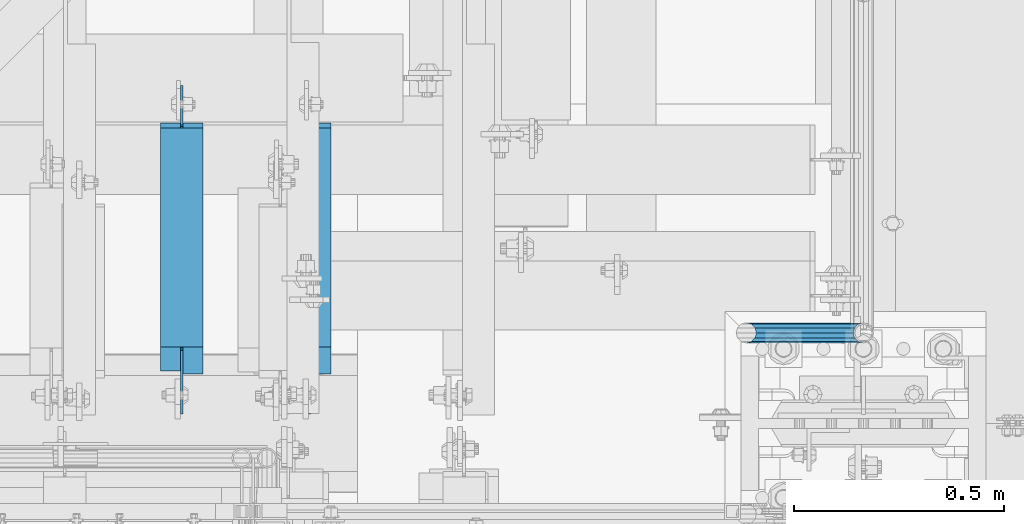
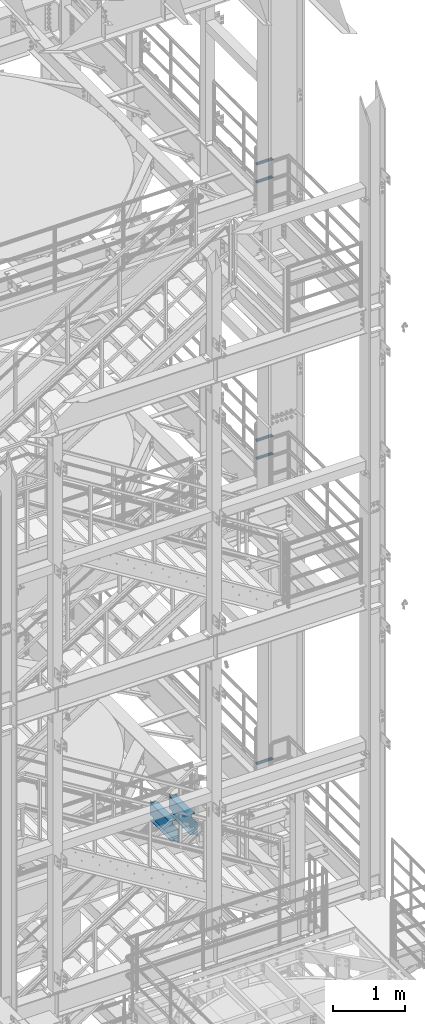
# One storey, part 1208 of 1876: 7 beams, 5 elements without a shape of their own.
"""IFC2X3 building model written with IfcOpenShell, lengths in millimetres."""

from ifc_helpers import new_model, si_unit, frame, origin_with_axes, place, context, subcontext, project, spatial, faceted_brep, material, type_object, element, aggregate, save


model = new_model("IFC2X3")

# Units and contexts
model_context = context("Model", 3, precision=1e-05, world=origin_with_axes())
body_context = subcontext(model_context, "Body", "Model", "MODEL_VIEW")
ifc_project = project(units=[si_unit("LENGTHUNIT", "METRE", prefix="MILLI"), si_unit("AREAUNIT", "SQUARE_METRE"), si_unit("VOLUMEUNIT", "CUBIC_METRE"), si_unit("MASSUNIT", "GRAM", prefix="KILO"), si_unit("TIMEUNIT", "SECOND"), si_unit("PLANEANGLEUNIT", "RADIAN"), si_unit("SOLIDANGLEUNIT", "STERADIAN"), si_unit("THERMODYNAMICTEMPERATUREUNIT", "DEGREE_CELSIUS"), si_unit("LUMINOUSINTENSITYUNIT", "LUMEN")], contexts=[model_context])

# Site, building, storey
site_placement = place(None, origin_with_axes())
site = spatial("IfcSite", under=ifc_project, at=site_placement, CompositionType="ELEMENT")
building_placement = place(site_placement, origin_with_axes())
building = spatial("IfcBuilding", under=site, at=building_placement, Name="Undefined", CompositionType="ELEMENT")
storey_placement = place(building_placement, origin_with_axes())
storey = spatial("IfcBuildingStorey", under=building, at=storey_placement, Name="Undefined", CompositionType="ELEMENT", Elevation=0.0)

# Assembly, beams
assembly_1_placement = place(storey_placement, origin_with_axes())
assembly_1 = element("IfcElementAssembly", 1, at=assembly_1_placement, inside=storey, Name="RAIL", AssemblyPlace="NOTDEFINED", PredefinedType="RIGID_FRAME")
ifc_material_1 = material()
beam_type_1 = type_object("IfcBeamType", Name="PIPE1-1/2SCH40", PredefinedType="NOTDEFINED")
beam_1_placement = place(assembly_1_placement, frame((7620.00000000001, -4356.1, 18449.925000036), z_axis=(0.0, 0.0, 1.0), x_axis=(-1.0, 0.0, 0.0)))
beam_1 = element("IfcBeam", 2, at=beam_1_placement, type_object=beam_type_1, material=ifc_material_1, Name="RAIL", ObjectType="PIPE1-1/2SCH40", context=body_context, shape_type="Brep", body=[
    faceted_brep([(258.502800903171, -12.0650000000005, 20.8971929933177), (258.502800903171, -12.0650000000005, 15.8661214311796), (258.009372465309, -10.2235000000001, 17.7076214311819), (255.26999389649, 0.0, 20.4470000000001), (255.26999389649, 0.0, 24.130000000001), (258.009372465309, 10.2235000000001, 17.7076214311819), (258.502800903171, 12.0650000000005, 15.8661214311796), (258.502800903171, 12.0650000000005, 20.8971929933177), (279.399993896489, 24.1299999999992, 0.0), (267.33499389649, 20.8971929933177, 12.0649999999987), (267.33499389649, 20.8971929933177, -12.0649999999987), (264.145422334351, 17.7076214311801, 10.2235000000001), (266.884800903171, 20.4470000000001, 0.0), (264.145422334351, 17.7076214311801, -10.2235000000001), (258.502800903171, 12.0650000000005, -15.8661214311796), (258.502800903171, 12.0650000000005, -20.8971929933177), (258.009372465309, 10.2235000000001, -17.7076214311819), (255.26999389649, 0.0, -20.4470000000001), (255.26999389649, 0.0, -24.130000000001), (258.502800903171, -12.0650000000005, -15.8661214311796), (258.502800903171, -12.0650000000005, -20.8971929933177), (258.009372465309, -10.2235000000001, -17.7076214311819), (279.399993896489, -24.1299999999992, 0.0), (267.33499389649, -20.8971929933177, -12.0649999999987), (267.33499389649, -20.8971929933177, 12.0649999999987), (264.145422334351, -17.7076214311801, -10.2235000000001), (266.884800903171, -20.4470000000001, 0.0), (264.145422334351, -17.7076214311801, 10.2235000000001), (12.0650000000064, -20.8971929933177, -12.0649999999987), (20.8971929933249, -12.0650000000005, -20.8971929933177), (0.0, 24.1299999999992, 0.0), (12.0650000000064, 20.8971929933177, -12.0649999999987), (12.0650000000064, 20.8971929933177, 12.0649999999987), (20.8971929933249, 12.0650000000005, 20.8971929933177), (24.1300000000064, 0.0, 24.130000000001), (20.8971929933249, 12.0650000000005, -20.8971929933177), (24.1300000000063, 0.0, -24.130000000001), (24.1300000000063, 0.0, -20.4470000000001), (20.8971929933249, -12.0650000000005, -15.8661214311796), (21.3906214311868, -10.2235000000001, -17.7076214311819), (21.3906214311868, 10.2235000000001, -17.7076214311819), (20.8971929933249, 12.0650000000005, -15.8661214311796), (15.2545715621445, 17.7076214311801, -10.2235000000001), (12.5151929933249, 20.4470000000001, 0.0), (15.2545715621445, 17.7076214311801, 10.2235000000001), (20.8971929933249, 12.0650000000005, 15.8661214311796), (21.3906214311868, 10.2235000000001, 17.7076214311819), (24.1300000000064, 0.0, 20.4470000000001), (21.3906214311868, -10.2235000000001, 17.7076214311819), (20.8971929933249, -12.0650000000005, 15.8661214311796), (20.8971929933249, -12.0650000000005, 20.8971929933177), (12.0650000000064, -20.8971929933177, 12.0649999999987), (0.0, -24.1299999999992, 0.0), (15.2545715621445, -17.7076214311801, 10.2235000000001), (12.5151929933249, -20.4470000000001, 0.0), (15.2545715621445, -17.7076214311801, -10.2235000000001)], [[[0, 1, 2, 3, 4]], [[4, 3, 5, 6, 7]], [[8, 9, 10]], [[7, 6, 11, 12, 13, 14, 15, 10, 9]], [[16, 17, 18, 15, 14]], [[19, 20, 18, 17, 21]], [[22, 23, 24]], [[24, 23, 20, 19, 25, 26, 27, 1, 0]], [[28, 29, 20, 23]], [[30, 31, 32]], [[33, 34, 4, 7]], [[32, 33, 7, 9]], [[30, 32, 9, 8]], [[31, 30, 8, 10]], [[35, 31, 10, 15]], [[36, 35, 15, 18]], [[29, 36, 18, 20]], [[37, 36, 29, 38, 39]], [[40, 41, 35, 36, 37]], [[32, 31, 35, 41, 42, 43, 44, 45, 33]], [[33, 45, 46, 47, 34]], [[34, 47, 48, 49, 50]], [[34, 50, 0, 4]], [[50, 51, 24, 0]], [[51, 52, 22, 24]], [[52, 28, 23, 22]], [[51, 28, 52]], [[50, 49, 53, 54, 55, 38, 29, 28, 51]], [[55, 54, 26, 25]], [[21, 39, 38, 55, 25, 19]], [[37, 39, 21, 17]], [[40, 37, 17, 16]], [[42, 41, 40, 16, 14, 13]], [[43, 42, 13, 12]], [[44, 43, 12, 11]], [[5, 46, 45, 44, 11, 6]], [[47, 46, 5, 3]], [[48, 47, 3, 2]], [[53, 49, 48, 2, 1, 27]], [[54, 53, 27, 26]]]),
])
beam_2_placement = place(assembly_1_placement, frame((7620.00000000001, -4356.1, 18754.7250000359), z_axis=(0.0, 0.0, 1.0), x_axis=(-1.0, 0.0, 0.0)))
beam_2 = element("IfcBeam", 3, at=beam_2_placement, type_object=beam_type_1, material=ifc_material_1, Name="RAIL", ObjectType="PIPE1-1/2SCH40", context=body_context, shape_type="Brep", body=[
    faceted_brep([(258.502800903171, -12.0650000000005, 20.8971929933177), (258.502800903171, -12.0650000000005, 15.8661214311796), (258.009372465309, -10.2235000000001, 17.7076214311819), (255.26999389649, 0.0, 20.4470000000001), (255.26999389649, 0.0, 24.130000000001), (258.009372465309, 10.2235000000001, 17.7076214311819), (258.502800903171, 12.0650000000005, 15.8661214311796), (258.502800903171, 12.0650000000005, 20.8971929933177), (279.399993896489, 24.1299999999992, 0.0), (267.33499389649, 20.8971929933177, 12.0649999999987), (267.33499389649, 20.8971929933177, -12.0649999999987), (264.145422334351, 17.7076214311801, 10.2235000000001), (266.884800903171, 20.4470000000001, 0.0), (264.145422334351, 17.7076214311801, -10.2235000000001), (258.502800903171, 12.0650000000005, -15.8661214311796), (258.502800903171, 12.0650000000005, -20.8971929933177), (258.009372465309, 10.2235000000001, -17.7076214311819), (255.26999389649, 0.0, -20.4470000000001), (255.26999389649, 0.0, -24.130000000001), (258.502800903171, -12.0650000000005, -15.8661214311796), (258.502800903171, -12.0650000000005, -20.8971929933177), (258.009372465309, -10.2235000000001, -17.7076214311819), (279.399993896489, -24.1299999999992, 0.0), (267.33499389649, -20.8971929933177, -12.0649999999987), (267.33499389649, -20.8971929933177, 12.0649999999987), (264.145422334351, -17.7076214311801, -10.2235000000001), (266.884800903171, -20.4470000000001, 0.0), (264.145422334351, -17.7076214311801, 10.2235000000001), (12.0650000000064, -20.8971929933177, -12.0649999999987), (20.8971929933249, -12.0650000000005, -20.8971929933177), (0.0, 24.1299999999992, 0.0), (12.0650000000064, 20.8971929933177, -12.0649999999987), (12.0650000000064, 20.8971929933177, 12.0649999999987), (20.8971929933249, 12.0650000000005, 20.8971929933177), (24.1300000000064, 0.0, 24.130000000001), (20.8971929933249, 12.0650000000005, -20.8971929933177), (24.1300000000063, 0.0, -24.130000000001), (24.1300000000063, 0.0, -20.4470000000001), (20.8971929933249, -12.0650000000005, -15.8661214311796), (21.3906214311868, -10.2235000000001, -17.7076214311819), (21.3906214311868, 10.2235000000001, -17.7076214311819), (20.8971929933249, 12.0650000000005, -15.8661214311796), (15.2545715621445, 17.7076214311801, -10.2235000000001), (12.5151929933249, 20.4470000000001, 0.0), (15.2545715621445, 17.7076214311801, 10.2235000000001), (20.8971929933249, 12.0650000000005, 15.8661214311796), (21.3906214311868, 10.2235000000001, 17.7076214311819), (24.1300000000064, 0.0, 20.4470000000001), (21.3906214311868, -10.2235000000001, 17.7076214311819), (20.8971929933249, -12.0650000000005, 15.8661214311796), (20.8971929933249, -12.0650000000005, 20.8971929933177), (12.0650000000064, -20.8971929933177, 12.0649999999987), (0.0, -24.1299999999992, 0.0), (15.2545715621445, -17.7076214311801, 10.2235000000001), (12.5151929933249, -20.4470000000001, 0.0), (15.2545715621445, -17.7076214311801, -10.2235000000001)], [[[0, 1, 2, 3, 4]], [[4, 3, 5, 6, 7]], [[8, 9, 10]], [[7, 6, 11, 12, 13, 14, 15, 10, 9]], [[16, 17, 18, 15, 14]], [[19, 20, 18, 17, 21]], [[22, 23, 24]], [[24, 23, 20, 19, 25, 26, 27, 1, 0]], [[28, 29, 20, 23]], [[30, 31, 32]], [[33, 34, 4, 7]], [[32, 33, 7, 9]], [[30, 32, 9, 8]], [[31, 30, 8, 10]], [[35, 31, 10, 15]], [[36, 35, 15, 18]], [[29, 36, 18, 20]], [[37, 36, 29, 38, 39]], [[40, 41, 35, 36, 37]], [[32, 31, 35, 41, 42, 43, 44, 45, 33]], [[33, 45, 46, 47, 34]], [[34, 47, 48, 49, 50]], [[34, 50, 0, 4]], [[50, 51, 24, 0]], [[51, 52, 22, 24]], [[52, 28, 23, 22]], [[51, 28, 52]], [[50, 49, 53, 54, 55, 38, 29, 28, 51]], [[55, 54, 26, 25]], [[21, 39, 38, 55, 25, 19]], [[37, 39, 21, 17]], [[40, 37, 17, 16]], [[42, 41, 40, 16, 14, 13]], [[43, 42, 13, 12]], [[44, 43, 12, 11]], [[5, 46, 45, 44, 11, 6]], [[47, 46, 5, 3]], [[48, 47, 3, 2]], [[53, 49, 48, 2, 1, 27]], [[54, 53, 27, 26]]]),
])
aggregate(assembly_1, [beam_1, beam_2])

assembly_2_placement = place(storey_placement, origin_with_axes())
assembly_2 = element("IfcElementAssembly", 4, at=assembly_2_placement, inside=storey, Name="RAIL", AssemblyPlace="NOTDEFINED", PredefinedType="RIGID_FRAME")
beam_3_placement = place(assembly_2_placement, frame((7620.00000000001, -4356.1, 13776.325000036), z_axis=(0.0, 0.0, 1.0), x_axis=(-1.0, 0.0, 0.0)))
beam_3 = element("IfcBeam", 5, at=beam_3_placement, type_object=beam_type_1, material=ifc_material_1, Name="RAIL", ObjectType="PIPE1-1/2SCH40", context=body_context, shape_type="Brep", body=[
    faceted_brep([(258.502800903171, -12.0650000000005, 20.8971929933177), (258.502800903171, -12.0650000000005, 15.8661214311796), (258.009372465309, -10.2235000000001, 17.7076214311819), (255.26999389649, 0.0, 20.4470000000001), (255.26999389649, 0.0, 24.130000000001), (258.009372465309, 10.2235000000001, 17.7076214311819), (258.502800903171, 12.0650000000005, 15.8661214311796), (258.502800903171, 12.0650000000005, 20.8971929933177), (279.399993896489, 24.1299999999992, 0.0), (267.33499389649, 20.8971929933177, 12.0649999999987), (267.33499389649, 20.8971929933177, -12.0649999999987), (264.145422334351, 17.7076214311801, 10.2235000000001), (266.884800903171, 20.4470000000001, 0.0), (264.145422334351, 17.7076214311801, -10.2235000000001), (258.502800903171, 12.0650000000005, -15.8661214311796), (258.502800903171, 12.0650000000005, -20.8971929933177), (258.009372465309, 10.2235000000001, -17.7076214311819), (255.26999389649, 0.0, -20.4470000000001), (255.26999389649, 0.0, -24.130000000001), (258.502800903171, -12.0650000000005, -15.8661214311796), (258.502800903171, -12.0650000000005, -20.8971929933177), (258.009372465309, -10.2235000000001, -17.7076214311819), (279.399993896489, -24.1299999999992, 0.0), (267.33499389649, -20.8971929933177, -12.0649999999987), (267.33499389649, -20.8971929933177, 12.0649999999987), (264.145422334351, -17.7076214311801, -10.2235000000001), (266.884800903171, -20.4470000000001, 0.0), (264.145422334351, -17.7076214311801, 10.2235000000001), (12.0650000000064, -20.8971929933177, -12.0649999999987), (20.8971929933249, -12.0650000000005, -20.8971929933177), (0.0, 24.1299999999992, 0.0), (12.0650000000064, 20.8971929933177, -12.0649999999987), (12.0650000000064, 20.8971929933177, 12.0649999999987), (20.8971929933249, 12.0650000000005, 20.8971929933177), (24.1300000000064, 0.0, 24.130000000001), (20.8971929933249, 12.0650000000005, -20.8971929933177), (24.1300000000063, 0.0, -24.130000000001), (24.1300000000063, 0.0, -20.4470000000001), (20.8971929933249, -12.0650000000005, -15.8661214311796), (21.3906214311868, -10.2235000000001, -17.7076214311819), (21.3906214311868, 10.2235000000001, -17.7076214311819), (20.8971929933249, 12.0650000000005, -15.8661214311796), (15.2545715621445, 17.7076214311801, -10.2235000000001), (12.5151929933249, 20.4470000000001, 0.0), (15.2545715621445, 17.7076214311801, 10.2235000000001), (20.8971929933249, 12.0650000000005, 15.8661214311796), (21.3906214311868, 10.2235000000001, 17.7076214311819), (24.1300000000064, 0.0, 20.4470000000001), (21.3906214311868, -10.2235000000001, 17.7076214311819), (20.8971929933249, -12.0650000000005, 15.8661214311796), (20.8971929933249, -12.0650000000005, 20.8971929933177), (12.0650000000064, -20.8971929933177, 12.0649999999987), (0.0, -24.1299999999992, 0.0), (15.2545715621445, -17.7076214311801, 10.2235000000001), (12.5151929933249, -20.4470000000001, 0.0), (15.2545715621445, -17.7076214311801, -10.2235000000001)], [[[0, 1, 2, 3, 4]], [[4, 3, 5, 6, 7]], [[8, 9, 10]], [[7, 6, 11, 12, 13, 14, 15, 10, 9]], [[16, 17, 18, 15, 14]], [[19, 20, 18, 17, 21]], [[22, 23, 24]], [[24, 23, 20, 19, 25, 26, 27, 1, 0]], [[28, 29, 20, 23]], [[30, 31, 32]], [[33, 34, 4, 7]], [[32, 33, 7, 9]], [[30, 32, 9, 8]], [[31, 30, 8, 10]], [[35, 31, 10, 15]], [[36, 35, 15, 18]], [[29, 36, 18, 20]], [[37, 36, 29, 38, 39]], [[40, 41, 35, 36, 37]], [[32, 31, 35, 41, 42, 43, 44, 45, 33]], [[33, 45, 46, 47, 34]], [[34, 47, 48, 49, 50]], [[34, 50, 0, 4]], [[50, 51, 24, 0]], [[51, 52, 22, 24]], [[52, 28, 23, 22]], [[51, 28, 52]], [[50, 49, 53, 54, 55, 38, 29, 28, 51]], [[55, 54, 26, 25]], [[21, 39, 38, 55, 25, 19]], [[37, 39, 21, 17]], [[40, 37, 17, 16]], [[42, 41, 40, 16, 14, 13]], [[43, 42, 13, 12]], [[44, 43, 12, 11]], [[5, 46, 45, 44, 11, 6]], [[47, 46, 5, 3]], [[48, 47, 3, 2]], [[53, 49, 48, 2, 1, 27]], [[54, 53, 27, 26]]]),
])
beam_4_placement = place(assembly_2_placement, frame((7620.00000000001, -4356.1, 14081.1250000359), z_axis=(0.0, 0.0, 1.0), x_axis=(-1.0, 0.0, 0.0)))
beam_4 = element("IfcBeam", 6, at=beam_4_placement, type_object=beam_type_1, material=ifc_material_1, Name="RAIL", ObjectType="PIPE1-1/2SCH40", context=body_context, shape_type="Brep", body=[
    faceted_brep([(258.502800903171, -12.0650000000005, 20.8971929933177), (258.502800903171, -12.0650000000005, 15.8661214311796), (258.009372465309, -10.2235000000001, 17.7076214311819), (255.26999389649, 0.0, 20.4470000000001), (255.26999389649, 0.0, 24.130000000001), (258.009372465309, 10.2235000000001, 17.7076214311819), (258.502800903171, 12.0650000000005, 15.8661214311796), (258.502800903171, 12.0650000000005, 20.8971929933177), (279.399993896489, 24.1299999999992, 0.0), (267.33499389649, 20.8971929933177, 12.0649999999987), (267.33499389649, 20.8971929933177, -12.0649999999987), (264.145422334351, 17.7076214311801, 10.2235000000001), (266.884800903171, 20.4470000000001, 0.0), (264.145422334351, 17.7076214311801, -10.2235000000001), (258.502800903171, 12.0650000000005, -15.8661214311796), (258.502800903171, 12.0650000000005, -20.8971929933177), (258.009372465309, 10.2235000000001, -17.7076214311819), (255.26999389649, 0.0, -20.4470000000001), (255.26999389649, 0.0, -24.130000000001), (258.502800903171, -12.0650000000005, -15.8661214311796), (258.502800903171, -12.0650000000005, -20.8971929933177), (258.009372465309, -10.2235000000001, -17.7076214311819), (279.399993896489, -24.1299999999992, 0.0), (267.33499389649, -20.8971929933177, -12.0649999999987), (267.33499389649, -20.8971929933177, 12.0649999999987), (264.145422334351, -17.7076214311801, -10.2235000000001), (266.884800903171, -20.4470000000001, 0.0), (264.145422334351, -17.7076214311801, 10.2235000000001), (12.0650000000064, -20.8971929933177, -12.0649999999987), (20.8971929933249, -12.0650000000005, -20.8971929933177), (0.0, 24.1299999999992, 0.0), (12.0650000000064, 20.8971929933177, -12.0649999999987), (12.0650000000064, 20.8971929933177, 12.0649999999987), (20.8971929933249, 12.0650000000005, 20.8971929933177), (24.1300000000064, 0.0, 24.130000000001), (20.8971929933249, 12.0650000000005, -20.8971929933177), (24.1300000000063, 0.0, -24.130000000001), (24.1300000000063, 0.0, -20.4470000000001), (20.8971929933249, -12.0650000000005, -15.8661214311796), (21.3906214311868, -10.2235000000001, -17.7076214311819), (21.3906214311868, 10.2235000000001, -17.7076214311819), (20.8971929933249, 12.0650000000005, -15.8661214311796), (15.2545715621445, 17.7076214311801, -10.2235000000001), (12.5151929933249, 20.4470000000001, 0.0), (15.2545715621445, 17.7076214311801, 10.2235000000001), (20.8971929933249, 12.0650000000005, 15.8661214311796), (21.3906214311868, 10.2235000000001, 17.7076214311819), (24.1300000000064, 0.0, 20.4470000000001), (21.3906214311868, -10.2235000000001, 17.7076214311819), (20.8971929933249, -12.0650000000005, 15.8661214311796), (20.8971929933249, -12.0650000000005, 20.8971929933177), (12.0650000000064, -20.8971929933177, 12.0649999999987), (0.0, -24.1299999999992, 0.0), (15.2545715621445, -17.7076214311801, 10.2235000000001), (12.5151929933249, -20.4470000000001, 0.0), (15.2545715621445, -17.7076214311801, -10.2235000000001)], [[[0, 1, 2, 3, 4]], [[4, 3, 5, 6, 7]], [[8, 9, 10]], [[7, 6, 11, 12, 13, 14, 15, 10, 9]], [[16, 17, 18, 15, 14]], [[19, 20, 18, 17, 21]], [[22, 23, 24]], [[24, 23, 20, 19, 25, 26, 27, 1, 0]], [[28, 29, 20, 23]], [[30, 31, 32]], [[33, 34, 4, 7]], [[32, 33, 7, 9]], [[30, 32, 9, 8]], [[31, 30, 8, 10]], [[35, 31, 10, 15]], [[36, 35, 15, 18]], [[29, 36, 18, 20]], [[37, 36, 29, 38, 39]], [[40, 41, 35, 36, 37]], [[32, 31, 35, 41, 42, 43, 44, 45, 33]], [[33, 45, 46, 47, 34]], [[34, 47, 48, 49, 50]], [[34, 50, 0, 4]], [[50, 51, 24, 0]], [[51, 52, 22, 24]], [[52, 28, 23, 22]], [[51, 28, 52]], [[50, 49, 53, 54, 55, 38, 29, 28, 51]], [[55, 54, 26, 25]], [[21, 39, 38, 55, 25, 19]], [[37, 39, 21, 17]], [[40, 37, 17, 16]], [[42, 41, 40, 16, 14, 13]], [[43, 42, 13, 12]], [[44, 43, 12, 11]], [[5, 46, 45, 44, 11, 6]], [[47, 46, 5, 3]], [[48, 47, 3, 2]], [[53, 49, 48, 2, 1, 27]], [[54, 53, 27, 26]]]),
])
aggregate(assembly_2, [beam_3, beam_4])

# Assembly, beam
assembly_3_placement = place(storey_placement, origin_with_axes())
assembly_3 = element("IfcElementAssembly", 7, at=assembly_3_placement, inside=storey, Name="RAIL", AssemblyPlace="NOTDEFINED", PredefinedType="RIGID_FRAME")
beam_5_placement = place(assembly_3_placement, frame((7620.00000000001, -4356.1, 8620.125000036), z_axis=(0.0, 0.0, 1.0), x_axis=(-1.0, 0.0, 0.0)))
beam_5 = element("IfcBeam", 8, at=beam_5_placement, type_object=beam_type_1, material=ifc_material_1, Name="RAIL", ObjectType="PIPE1-1/2SCH40", context=body_context, shape_type="Brep", body=[
    faceted_brep([(258.502800903171, -12.0650000000005, 20.8971929933177), (258.502800903171, -12.0650000000005, 15.8661214311796), (258.009372465309, -10.2235000000001, 17.7076214311819), (255.26999389649, 0.0, 20.4470000000001), (255.26999389649, 0.0, 24.130000000001), (258.009372465309, 10.2235000000001, 17.7076214311819), (258.502800903171, 12.0650000000005, 15.8661214311796), (258.502800903171, 12.0650000000005, 20.8971929933177), (279.399993896489, 24.1299999999992, 0.0), (267.33499389649, 20.8971929933177, 12.0649999999987), (267.33499389649, 20.8971929933177, -12.0649999999987), (264.145422334351, 17.7076214311801, 10.2235000000001), (266.884800903171, 20.4470000000001, 0.0), (264.145422334351, 17.7076214311801, -10.2235000000001), (258.502800903171, 12.0650000000005, -15.8661214311796), (258.502800903171, 12.0650000000005, -20.8971929933177), (258.009372465309, 10.2235000000001, -17.7076214311819), (255.26999389649, 0.0, -20.4470000000001), (255.26999389649, 0.0, -24.130000000001), (258.502800903171, -12.0650000000005, -15.8661214311796), (258.502800903171, -12.0650000000005, -20.8971929933177), (258.009372465309, -10.2235000000001, -17.7076214311819), (279.399993896489, -24.1299999999992, 0.0), (267.33499389649, -20.8971929933177, -12.0649999999987), (267.33499389649, -20.8971929933177, 12.0649999999987), (264.145422334351, -17.7076214311801, -10.2235000000001), (266.884800903171, -20.4470000000001, 0.0), (264.145422334351, -17.7076214311801, 10.2235000000001), (12.0650000000064, -20.8971929933177, -12.0649999999987), (20.8971929933249, -12.0650000000005, -20.8971929933177), (0.0, 24.1299999999992, 0.0), (12.0650000000064, 20.8971929933177, -12.0649999999987), (12.0650000000064, 20.8971929933177, 12.0649999999987), (20.8971929933249, 12.0650000000005, 20.8971929933177), (24.1300000000064, 0.0, 24.130000000001), (20.8971929933249, 12.0650000000005, -20.8971929933177), (24.1300000000063, 0.0, -24.130000000001), (24.1300000000063, 0.0, -20.4470000000001), (20.8971929933249, -12.0650000000005, -15.8661214311796), (21.3906214311868, -10.2235000000001, -17.7076214311819), (21.3906214311868, 10.2235000000001, -17.7076214311819), (20.8971929933249, 12.0650000000005, -15.8661214311796), (15.2545715621445, 17.7076214311801, -10.2235000000001), (12.5151929933249, 20.4470000000001, 0.0), (15.2545715621445, 17.7076214311801, 10.2235000000001), (20.8971929933249, 12.0650000000005, 15.8661214311796), (21.3906214311868, 10.2235000000001, 17.7076214311819), (24.1300000000064, 0.0, 20.4470000000001), (21.3906214311868, -10.2235000000001, 17.7076214311819), (20.8971929933249, -12.0650000000005, 15.8661214311796), (20.8971929933249, -12.0650000000005, 20.8971929933177), (12.0650000000064, -20.8971929933177, 12.0649999999987), (0.0, -24.1299999999992, 0.0), (15.2545715621445, -17.7076214311801, 10.2235000000001), (12.5151929933249, -20.4470000000001, 0.0), (15.2545715621445, -17.7076214311801, -10.2235000000001)], [[[0, 1, 2, 3, 4]], [[4, 3, 5, 6, 7]], [[8, 9, 10]], [[7, 6, 11, 12, 13, 14, 15, 10, 9]], [[16, 17, 18, 15, 14]], [[19, 20, 18, 17, 21]], [[22, 23, 24]], [[24, 23, 20, 19, 25, 26, 27, 1, 0]], [[28, 29, 20, 23]], [[30, 31, 32]], [[33, 34, 4, 7]], [[32, 33, 7, 9]], [[30, 32, 9, 8]], [[31, 30, 8, 10]], [[35, 31, 10, 15]], [[36, 35, 15, 18]], [[29, 36, 18, 20]], [[37, 36, 29, 38, 39]], [[40, 41, 35, 36, 37]], [[32, 31, 35, 41, 42, 43, 44, 45, 33]], [[33, 45, 46, 47, 34]], [[34, 47, 48, 49, 50]], [[34, 50, 0, 4]], [[50, 51, 24, 0]], [[51, 52, 22, 24]], [[52, 28, 23, 22]], [[51, 28, 52]], [[50, 49, 53, 54, 55, 38, 29, 28, 51]], [[55, 54, 26, 25]], [[21, 39, 38, 55, 25, 19]], [[37, 39, 21, 17]], [[40, 37, 17, 16]], [[42, 41, 40, 16, 14, 13]], [[43, 42, 13, 12]], [[44, 43, 12, 11]], [[5, 46, 45, 44, 11, 6]], [[47, 46, 5, 3]], [[48, 47, 3, 2]], [[53, 49, 48, 2, 1, 27]], [[54, 53, 27, 26]]]),
])
aggregate(assembly_3, [beam_5])

assembly_4_placement = place(storey_placement, origin_with_axes())
assembly_4 = element("IfcElementAssembly", 9, at=assembly_4_placement, inside=storey, Name="BEAM", AssemblyPlace="NOTDEFINED", PredefinedType="RIGID_FRAME")
ifc_material_2 = material(Name="STEEL/A992")
beam_type_2 = type_object("IfcBeamType", Name="W12X16", PredefinedType="NOTDEFINED")
beam_6_placement = place(assembly_4_placement, frame((6299.2, -4572.0, 8001.0), z_axis=(0.0, 0.0, 1.0), x_axis=(0.0, 1.0, 0.0)))
beam_6 = element("IfcBeam", 10, at=beam_6_placement, type_object=beam_type_2, material=ifc_material_2, Name="BEAM", ObjectType="W12X16", context=body_context, shape_type="Brep", body=[
    faceted_brep([(716.75625, -3.17500000000018, -146.05), (716.75625, -50.8000000000002, -146.05), (716.75625, -50.8000000000002, -152.4), (716.75625, 50.8000000000002, -152.4), (716.75625, 50.8000000000002, -146.05), (716.75625, 3.17500001244935, -146.05), (716.75625, 3.17500003927307, -139.699999809264), (716.75625, -3.17500000000018, -139.699999809264), (717.722979922588, 3.17500003847817, -134.839920291219), (717.722979922588, -3.17500000000018, -134.839920291219), (720.475993823066, 3.17500003779696, -130.719743823065), (720.475993823066, -3.17500000000018, -130.719743823065), (724.59617029122, 3.17500003733312, -127.966729922587), (724.59617029122, -3.17500000000018, -127.966729922587), (729.456249809265, 3.17500003715577, -126.999999999999), (729.456249809265, -3.17500000000018, -126.999999999999), (805.65625, -3.17500000000018, -126.999999999999), (805.65625, 3.17500000000018, -126.999999999999), (181.768749999998, 3.17499999999995, 146.05), (181.768749999998, 50.8, 146.05), (704.05625, 50.8000000000002, 146.05), (704.05625, 3.17500000000018, 146.05), (124.61875, 50.8, -146.05), (124.61875, 50.8, -152.4), (124.61875, 3.17500009536752, -152.4), (124.61875, 3.17500009536752, -146.05), (118.268749999998, 3.17500009536752, -152.4), (118.268749999998, 3.17500008940715, -146.05), (118.268749999998, -3.17499999999995, -139.699999809265), (118.268749999998, 3.17500002616043, -139.699999809265), (118.268749999998, -50.8, -152.4), (118.268749999998, -50.8, -146.05), (118.268749999998, -3.17499999999995, -146.05), (117.302020077411, -3.17499999999995, -134.83992029122), (117.302020077411, 3.17500002537099, -134.83992029122), (114.549006176932, -3.17499999999995, -130.719743823066), (114.549006176932, 3.17500002470138, -130.719743823066), (110.428829708779, -3.17499999999995, -127.966729922588), (110.428829708779, 3.17500002425345, -127.966729922588), (105.568750190733, -3.17499999999995, -127.0), (105.568750190733, 3.17500002409543, -127.0), (23.0187500000002, -3.17499999999995, -127.0), (23.0187500000002, 3.17499999999995, -127.0), (23.0187500000002, -3.17499999999995, 101.6), (23.0187500000002, 3.17499999999995, 101.6), (169.068750190733, -3.17499999999995, 101.6), (169.068750190733, 3.17499998798007, 101.6), (173.928829708779, -3.17499999999995, 102.566729922588), (173.928829708779, 3.17499998782432, 102.566729922588), (178.049006176932, -3.17499999999995, 105.319743823066), (178.049006176932, 3.17499998738072, 105.319743823066), (180.802020077411, -3.17499999999995, 109.43992029122), (180.802020077411, 3.17499998671678, 109.43992029122), (181.768749999998, -3.17499999999995, 114.299999809266), (181.768749999998, 3.17499998593348, 114.299999809266), (181.768749999998, -50.8, 152.4), (181.768749999998, 50.8, 152.4), (181.768749999998, -3.17499999999995, 146.05), (181.768749999998, -50.8, 146.05), (704.05625, -3.17500000000018, 146.05), (704.05625, -50.8000000000002, 146.05), (704.05625, -50.8000000000002, 152.4), (704.05625, 50.8000000000002, 152.4), (704.05625, -3.17500000000018, 133.349999809266), (704.05625, 3.1749999952408, 133.349999809266), (705.022979922588, -3.17500000000018, 128.48992029122), (705.022979922588, 3.17499999601478, 128.48992029122), (707.775993823066, -3.17500000000018, 124.369743823067), (707.775993823066, 3.17499999666416, 124.369743823067), (711.89617029122, -3.17500000000018, 121.616729922588), (711.89617029122, 3.1749999970898, 121.616729922588), (716.756249809265, -3.17500000000018, 120.650000000001), (716.756249809265, 3.17499999722713, 120.650000000001), (805.65625, -3.17500000000018, 120.650000000001), (805.65625, 3.17500000000018, 120.650000000001)], [[[0, 1, 2, 3, 4, 5, 6, 7]], [[7, 6, 8, 9]], [[9, 8, 10, 11]], [[11, 10, 12, 13]], [[13, 12, 14, 15]], [[16, 15, 14, 17]], [[18, 19, 20, 21]], [[22, 23, 24, 25]], [[25, 24, 26, 27]], [[28, 29, 27, 26, 30, 31, 32]], [[33, 34, 29, 28]], [[35, 36, 34, 33]], [[37, 38, 36, 35]], [[39, 40, 38, 37]], [[41, 42, 40, 39]], [[43, 44, 42, 41]], [[45, 46, 44, 43]], [[47, 48, 46, 45]], [[49, 50, 48, 47]], [[51, 52, 50, 49]], [[53, 54, 52, 51]], [[55, 56, 19, 18, 54, 53, 57, 58]], [[58, 57, 59, 60]], [[55, 58, 60, 61]], [[56, 55, 61, 62]], [[19, 56, 62, 20]], [[61, 60, 59, 63, 64, 21, 20, 62]], [[65, 66, 64, 63]], [[67, 68, 66, 65]], [[69, 70, 68, 67]], [[71, 72, 70, 69]], [[73, 74, 72, 71]], [[74, 73, 16, 17]], [[12, 10, 8, 6, 5, 25, 27, 29, 34, 36, 38, 40, 42, 44, 46, 48, 50, 52, 54, 18, 21, 64, 66, 68, 70, 72, 74, 17, 14]], [[22, 25, 5, 4]], [[23, 22, 4, 3]], [[30, 26, 24, 23, 3, 2]], [[31, 30, 2, 1]], [[32, 31, 1, 0]], [[73, 71, 69, 67, 65, 63, 59, 57, 53, 51, 49, 47, 45, 43, 41, 39, 37, 35, 33, 28, 32, 0, 7, 9, 11, 13, 15, 16]]]),
])
aggregate(assembly_4, [beam_6])

assembly_5_placement = place(storey_placement, origin_with_axes())
assembly_5 = element("IfcElementAssembly", 11, at=assembly_5_placement, inside=storey, Name="BEAM", AssemblyPlace="NOTDEFINED", PredefinedType="RIGID_FRAME")
beam_7_placement = place(assembly_5_placement, frame((5994.4, -4572.0, 8001.0), z_axis=(0.0, 0.0, 1.0), x_axis=(0.0, 1.0, 0.0)))
beam_7 = element("IfcBeam", 12, at=beam_7_placement, type_object=beam_type_2, material=ifc_material_2, Name="BEAM", ObjectType="W12X16", context=body_context, shape_type="Brep", body=[
    faceted_brep([(716.75625, -3.17500000000018, -146.05), (716.75625, -50.8000000000002, -146.05), (716.75625, -50.8000000000002, -152.4), (716.75625, 50.8000000000002, -152.4), (716.75625, 50.8000000000002, -146.05), (716.75625, 3.17500001244935, -146.05), (716.75625, 3.17500003927307, -139.699999809264), (716.75625, -3.17500000000018, -139.699999809264), (717.722979922588, 3.17500003847817, -134.839920291219), (717.722979922588, -3.17500000000018, -134.839920291219), (720.475993823066, 3.17500003779696, -130.719743823065), (720.475993823066, -3.17500000000018, -130.719743823065), (724.59617029122, 3.17500003733312, -127.966729922587), (724.59617029122, -3.17500000000018, -127.966729922587), (729.456249809265, 3.17500003715577, -126.999999999999), (729.456249809265, -3.17500000000018, -126.999999999999), (805.65625, -3.17500000000018, -126.999999999999), (805.65625, 3.17500000000018, -126.999999999999), (181.768749999998, 3.17499999999995, 146.05), (181.768749999998, 50.8, 146.05), (704.05625, 50.8000000000002, 146.05), (704.05625, 3.17500000000018, 146.05), (124.61875, 50.8, -146.05), (124.61875, 50.8, -152.4), (124.61875, 3.17500009536752, -152.4), (124.61875, 3.17500009536752, -146.05), (118.268749999998, 3.17500009536752, -152.4), (118.268749999998, 3.17500008940715, -146.05), (118.268749999998, -3.17499999999995, -139.699999809265), (118.268749999998, 3.17500002616043, -139.699999809265), (118.268749999998, -50.8, -152.4), (118.268749999998, -50.8, -146.05), (118.268749999998, -3.17499999999995, -146.05), (117.302020077411, -3.17499999999995, -134.83992029122), (117.302020077411, 3.17500002537099, -134.83992029122), (114.549006176932, -3.17499999999995, -130.719743823066), (114.549006176932, 3.17500002470138, -130.719743823066), (110.428829708779, -3.17499999999995, -127.966729922588), (110.428829708779, 3.17500002425345, -127.966729922588), (105.568750190733, -3.17499999999995, -127.0), (105.568750190733, 3.17500002409543, -127.0), (23.0187500000002, -3.17499999999995, -127.0), (23.0187500000002, 3.17499999999995, -127.0), (23.0187500000002, -3.17499999999995, 101.6), (23.0187500000002, 3.17499999999995, 101.6), (169.068750190733, -3.17499999999995, 101.6), (169.068750190733, 3.17499998798007, 101.6), (173.928829708779, -3.17499999999995, 102.566729922588), (173.928829708779, 3.17499998782432, 102.566729922588), (178.049006176932, -3.17499999999995, 105.319743823066), (178.049006176932, 3.17499998738072, 105.319743823066), (180.802020077411, -3.17499999999995, 109.43992029122), (180.802020077411, 3.17499998671678, 109.43992029122), (181.768749999998, -3.17499999999995, 114.299999809266), (181.768749999998, 3.17499998593348, 114.299999809266), (181.768749999998, -50.8, 152.4), (181.768749999998, 50.8, 152.4), (181.768749999998, -3.17499999999995, 146.05), (181.768749999998, -50.8, 146.05), (704.05625, -3.17500000000018, 146.05), (704.05625, -50.8000000000002, 146.05), (704.05625, -50.8000000000002, 152.4), (704.05625, 50.8000000000002, 152.4), (704.05625, -3.17500000000018, 133.349999809266), (704.05625, 3.1749999952408, 133.349999809266), (705.022979922588, -3.17500000000018, 128.48992029122), (705.022979922588, 3.17499999601478, 128.48992029122), (707.775993823066, -3.17500000000018, 124.369743823067), (707.775993823066, 3.17499999666416, 124.369743823067), (711.89617029122, -3.17500000000018, 121.616729922588), (711.89617029122, 3.1749999970898, 121.616729922588), (716.756249809265, -3.17500000000018, 120.650000000001), (716.756249809265, 3.17499999722713, 120.650000000001), (805.65625, -3.17500000000018, 120.650000000001), (805.65625, 3.17500000000018, 120.650000000001)], [[[0, 1, 2, 3, 4, 5, 6, 7]], [[7, 6, 8, 9]], [[9, 8, 10, 11]], [[11, 10, 12, 13]], [[13, 12, 14, 15]], [[16, 15, 14, 17]], [[18, 19, 20, 21]], [[22, 23, 24, 25]], [[25, 24, 26, 27]], [[28, 29, 27, 26, 30, 31, 32]], [[33, 34, 29, 28]], [[35, 36, 34, 33]], [[37, 38, 36, 35]], [[39, 40, 38, 37]], [[41, 42, 40, 39]], [[43, 44, 42, 41]], [[45, 46, 44, 43]], [[47, 48, 46, 45]], [[49, 50, 48, 47]], [[51, 52, 50, 49]], [[53, 54, 52, 51]], [[55, 56, 19, 18, 54, 53, 57, 58]], [[58, 57, 59, 60]], [[55, 58, 60, 61]], [[56, 55, 61, 62]], [[19, 56, 62, 20]], [[61, 60, 59, 63, 64, 21, 20, 62]], [[65, 66, 64, 63]], [[67, 68, 66, 65]], [[69, 70, 68, 67]], [[71, 72, 70, 69]], [[73, 74, 72, 71]], [[74, 73, 16, 17]], [[12, 10, 8, 6, 5, 25, 27, 29, 34, 36, 38, 40, 42, 44, 46, 48, 50, 52, 54, 18, 21, 64, 66, 68, 70, 72, 74, 17, 14]], [[22, 25, 5, 4]], [[23, 22, 4, 3]], [[30, 26, 24, 23, 3, 2]], [[31, 30, 2, 1]], [[32, 31, 1, 0]], [[73, 71, 69, 67, 65, 63, 59, 57, 53, 51, 49, 47, 45, 43, 41, 39, 37, 35, 33, 28, 32, 0, 7, 9, 11, 13, 15, 16]]]),
])
aggregate(assembly_5, [beam_7])

save(model, "model.ifc")
